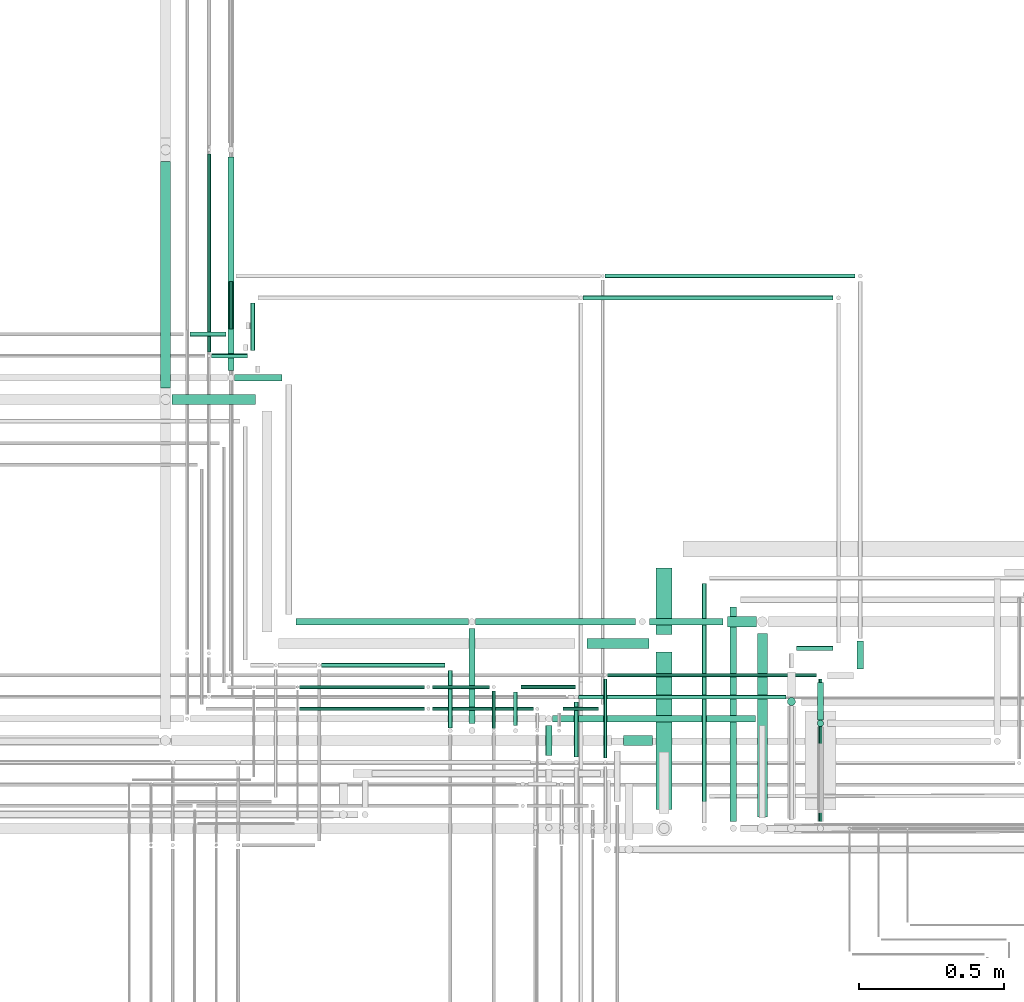
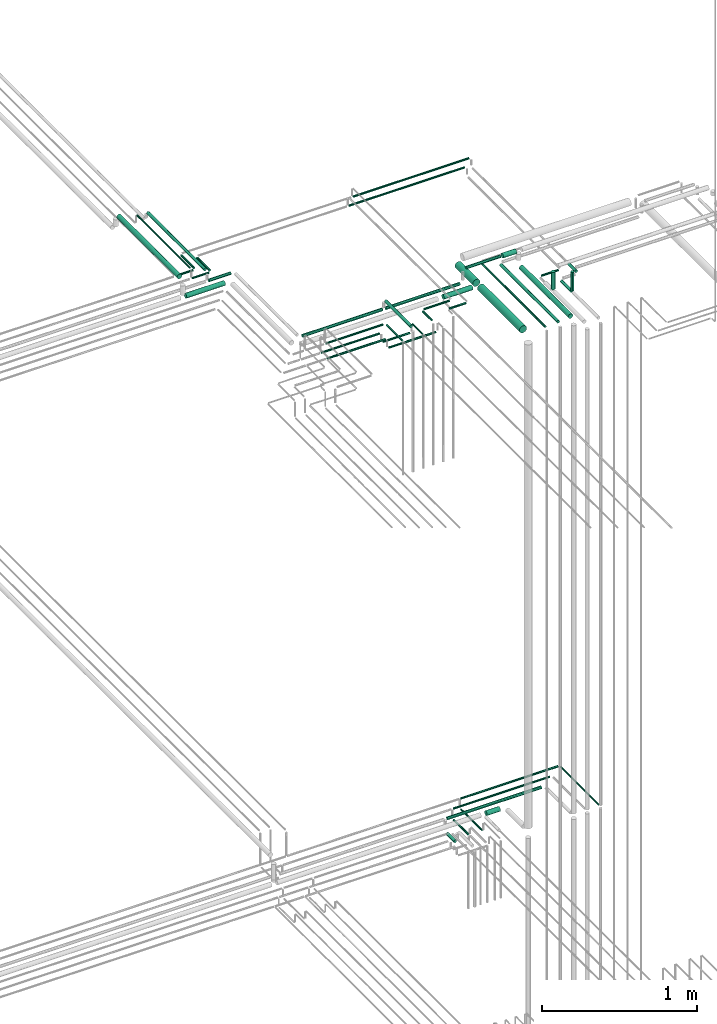
# One storey, part 226 of 331: 45 flow segments.
"""IFC2X3 building model written with IfcOpenShell, lengths in millimetres."""

import ifcopenshell
import ifcopenshell.guid

model = None  # the IFC model being written
_history = None  # IfcOwnerHistory: only IFC2X3 demands one
_inside = {}  # id of a spatial element -> (the spatial element, [elements in it])
_under = {}  # id of a project, library or spatial element -> (it, [spatial elements below it])
_declared = {}  # id of a project -> (the project, [libraries it declares])
_typed = {}  # id of a type object -> (the type object, [elements of that type])
_made_of = {}  # id of a material, layer set ... -> (it, [elements and type objects made of it])


def new_model(schema):
    """Start an empty IFC model of exactly this schema.

    Asked for "IFC4X3", IfcOpenShell would pick the latest addendum, in which some entities
    have other attributes; the version numbers below select the first issue.
    IFC2X3 requires an IfcOwnerHistory on every rooted entity: one is made here for all.
    """
    global model, _history
    if schema == "IFC4X3":
        model = ifcopenshell.file(schema_version=(4, 3, 0, 0))
    else:
        model = ifcopenshell.file(schema=schema)
    _inside.clear()
    _under.clear()
    _declared.clear()
    _typed.clear()
    _made_of.clear()
    _history = None
    if model.schema == "IFC2X3":
        org = make("IfcOrganization", Name="unknown")
        user = make(
            "IfcPersonAndOrganization",
            ThePerson=make("IfcPerson", FamilyName="unknown"),
            TheOrganization=org,
        )
        app = make(
            "IfcApplication",
            ApplicationDeveloper=org,
            Version="unknown",
            ApplicationFullName="unknown",
            ApplicationIdentifier="unknown",
        )
        _history = make(
            "IfcOwnerHistory",
            OwningUser=user,
            OwningApplication=app,
            ChangeAction="ADDED",
            CreationDate=0,
        )
    return model


def make(cls, **values):
    """One entity of the class cls with the attributes given. An attribute that is None is left unset."""
    return model.create_entity(
        cls, **{name: value for name, value in values.items() if value is not None}
    )


def entity(cls, *values):
    """Any entity or typed value of the class cls, its attributes in the order of the schema. None: left unset."""
    e = model.create_entity(cls)
    for i, value in enumerate(values):
        if value is not None:
            e[i] = value
    return e


def rooted(cls, **values):
    """An entity with a GlobalId (a new one), such as an element, a storey or a relation."""
    return make(cls, GlobalId=ifcopenshell.guid.new(), OwnerHistory=_history, **values)


def si_unit(unit_type, name, prefix=None):
    """IfcSIUnit, for example si_unit("LENGTHUNIT", "METRE", prefix="MILLI")."""
    return make("IfcSIUnit", UnitType=unit_type, Prefix=prefix, Name=name)


def converted_unit(unit_type, name, factor, base, dimensions=None, offset=None):
    """IfcConversionBasedUnit, such as the inch: factor (a typed value) times the base unit."""
    return make(
        "IfcConversionBasedUnit"
        if offset is None
        else "IfcConversionBasedUnitWithOffset",
        ConversionOffset=offset,
        Dimensions=None
        if dimensions is None
        else entity("IfcDimensionalExponents", *dimensions),
        UnitType=unit_type,
        Name=name,
        ConversionFactor=make(
            "IfcMeasureWithUnit", ValueComponent=factor, UnitComponent=base
        ),
    )


def derived_unit(unit_type, elements):
    """IfcDerivedUnit: a product of units, each with its exponent."""
    return make(
        "IfcDerivedUnit",
        Elements=[
            make("IfcDerivedUnitElement", Unit=unit, Exponent=power)
            for unit, power in elements
        ],
        UnitType=unit_type,
    )


def assignment(units):
    """IfcUnitAssignment: the units of a project."""
    return None if units is None else make("IfcUnitAssignment", Units=units)


def point(xyz):
    """IfcCartesianPoint."""
    return None if xyz is None else make("IfcCartesianPoint", Coordinates=xyz)


def direction(xyz):
    """IfcDirection."""
    return None if xyz is None else make("IfcDirection", DirectionRatios=xyz)


def frame(location, z_axis=None, x_axis=None):
    """IfcAxis2Placement3D, a coordinate frame: its origin and axes. An axis left out is left unset."""
    return make(
        "IfcAxis2Placement3D",
        Location=point(location),
        Axis=direction(z_axis),
        RefDirection=direction(x_axis),
    )


def frame_2d(location, x_axis=None):
    """IfcAxis2Placement2D, a coordinate frame in the plane: its origin and x axis."""
    return make(
        "IfcAxis2Placement2D", Location=point(location), RefDirection=direction(x_axis)
    )


def origin():
    """The frame at (0, 0, 0) with its axes left unset."""
    return frame((0.0, 0.0, 0.0))


def origin_2d_with_axis():
    """The frame at (0, 0) in the plane with the x axis (1, 0) written out."""
    return frame_2d((0.0, 0.0), x_axis=(1.0, 0.0))


def place(relative_to, where):
    """IfcLocalPlacement: puts the frame where relative to a parent placement (None: the world)."""
    return make(
        "IfcLocalPlacement", PlacementRelTo=relative_to, RelativePlacement=where
    )


def context(
    kind, dimensions, precision=None, world=None, true_north=None, identifier=None
):
    """IfcGeometricRepresentationContext, for example the 3D "Model" context."""
    return make(
        "IfcGeometricRepresentationContext",
        ContextIdentifier=identifier,
        ContextType=kind,
        CoordinateSpaceDimension=dimensions,
        Precision=precision,
        WorldCoordinateSystem=world,
        TrueNorth=true_north,
    )


def subcontext(parent, identifier, kind, view, scale=None):
    """IfcGeometricRepresentationSubContext, for example "Body" below "Model"."""
    return make(
        "IfcGeometricRepresentationSubContext",
        ContextIdentifier=identifier,
        ContextType=kind,
        ParentContext=parent,
        TargetScale=scale,
        TargetView=view,
    )


def project(units=None, contexts=None):
    """IfcProject with its units and contexts."""
    return rooted(
        "IfcProject",
        Name="project",
        RepresentationContexts=contexts,
        UnitsInContext=assignment(units),
    )


def spatial(cls, under=None, at=None, **own):
    """A site, building, storey or space (cls), placed at a placement, below another one or the project."""
    s = rooted(cls, ObjectPlacement=at, **own)
    if under is not None:
        _under.setdefault(under.id(), (under, []))[1].append(s)
    return s


def profile(cls, at=None, kind="AREA", **sizes):
    """A parametric profile (cls). Its sizes go by their IFC names, for example OverallWidth=200.0."""
    return make(cls, ProfileType=kind, Position=at, **sizes)


def circle(**sizes):
    """IfcCircleProfileDef."""
    return profile("IfcCircleProfileDef", **sizes)


def extrude(swept, where, along, depth):
    """IfcExtrudedAreaSolid: the profile swept, set in the frame where, extruded along a direction by depth."""
    return make(
        "IfcExtrudedAreaSolid",
        SweptArea=swept,
        Position=where,
        ExtrudedDirection=direction(along),
        Depth=depth,
    )


def shape(context_of_items, identifier, shape_type, items):
    """IfcShapeRepresentation: the items that make up one representation, for example the "Body"."""
    return make(
        "IfcShapeRepresentation",
        ContextOfItems=context_of_items,
        RepresentationIdentifier=identifier,
        RepresentationType=shape_type,
        Items=items,
    )


def made_of(thing, what):
    """Note that an element or type object is made of a material, layer set ...; save() writes the relation."""
    if what is not None:
        _made_of.setdefault(what.id(), (what, []))[1].append(thing)
    return thing


def type_object(cls, material=None, **own):
    """A type object (cls), such as IfcWallType, which elements share."""
    return made_of(rooted(cls, **own), material)


def element(
    cls,
    number,
    at=None,
    inside=None,
    cuts=None,
    type_object=None,
    material=None,
    context=None,
    identifier="Body",
    shape_type=None,
    held_by="IfcProductDefinitionShape",
    body=None,
    shapes=None,
    **own,
):
    """One element of the class cls, such as IfcWall. Its Tag is "e" and its number.

    at: its placement. inside: the storey or other place that contains it. cuts: it is an
    opening in that element (IfcRelVoidsElement). A single representation is given by context,
    identifier, shape_type and body (its items); several are given by shapes. held_by: the class
    of the entity that holds the representations. save() writes the other relations.
    """
    e = rooted(cls, Tag="e%d" % number, ObjectPlacement=at, **own)
    if body is not None:
        shapes = [shape(context, identifier, shape_type, body)]
    if shapes is not None:
        e.Representation = make(held_by, Representations=shapes)
    if inside is not None:
        _inside.setdefault(inside.id(), (inside, []))[1].append(e)
    if cuts is not None:
        rooted(
            "IfcRelVoidsElement", RelatingBuildingElement=cuts, RelatedOpeningElement=e
        )
    if type_object is not None:
        _typed.setdefault(type_object.id(), (type_object, []))[1].append(e)
    return made_of(e, material)


def aggregate(whole, parts):
    """IfcRelAggregates: a whole, such as a stair, and the parts it consists of."""
    return rooted("IfcRelAggregates", RelatingObject=whole, RelatedObjects=parts)


def save(model, path):
    """Write the relations noted so far, then the file.

    IfcRelAggregates (storeys below a building ...), IfcRelContainedInSpatialStructure (elements
    in a storey), IfcRelDefinesByType, IfcRelAssociatesMaterial and IfcRelDeclares: one each for
    every whole, place, type object, material and project.
    """
    for whole, parts in _under.values():
        aggregate(whole, parts)
    for where, things in _inside.values():
        rooted(
            "IfcRelContainedInSpatialStructure",
            RelatedElements=things,
            RelatingStructure=where,
        )
    for kind, things in _typed.values():
        rooted("IfcRelDefinesByType", RelatedObjects=things, RelatingType=kind)
    for what, things in _made_of.values():
        rooted("IfcRelAssociatesMaterial", RelatedObjects=things, RelatingMaterial=what)
    for by, libraries in _declared.values():
        rooted("IfcRelDeclares", RelatingContext=by, RelatedDefinitions=libraries)
    model.write(path)


model = new_model("IFC2X3")

# Units and contexts
model_context = context("Model", 3, precision=0.01, world=origin(), true_north=direction((6.12303176911189e-17, 1.0)))
body_context = subcontext(model_context, "Body", "Model", "MODEL_VIEW")
ifc_project = project(units=[si_unit("LENGTHUNIT", "METRE", prefix="MILLI"), si_unit("AREAUNIT", "SQUARE_METRE"), si_unit("VOLUMEUNIT", "CUBIC_METRE"), converted_unit("PLANEANGLEUNIT", "DEGREE", entity("IfcRatioMeasure", 0.0174532925199433), si_unit("PLANEANGLEUNIT", "RADIAN"), dimensions=[0, 0, 0, 0, 0, 0, 0]), si_unit("MASSUNIT", "GRAM", prefix="KILO"), derived_unit("MASSDENSITYUNIT", [(si_unit("MASSUNIT", "GRAM", prefix="KILO"), 1), (si_unit("LENGTHUNIT", "METRE"), -3)]), derived_unit("MOMENTOFINERTIAUNIT", [(si_unit("LENGTHUNIT", "METRE"), 4)]), si_unit("TIMEUNIT", "SECOND"), si_unit("FREQUENCYUNIT", "HERTZ"), si_unit("THERMODYNAMICTEMPERATUREUNIT", "DEGREE_CELSIUS"), derived_unit("THERMALTRANSMITTANCEUNIT", [(si_unit("MASSUNIT", "GRAM", prefix="KILO"), 1), (si_unit("THERMODYNAMICTEMPERATUREUNIT", "KELVIN"), -1), (si_unit("TIMEUNIT", "SECOND"), -3)]), derived_unit("VOLUMETRICFLOWRATEUNIT", [(si_unit("LENGTHUNIT", "METRE"), 3), (si_unit("TIMEUNIT", "SECOND"), -1)]), derived_unit("MASSFLOWRATEUNIT", [(si_unit("MASSUNIT", "GRAM", prefix="KILO"), 1), (si_unit("TIMEUNIT", "SECOND"), -1)]), derived_unit("ROTATIONALFREQUENCYUNIT", [(si_unit("TIMEUNIT", "SECOND"), -1)]), si_unit("ELECTRICCURRENTUNIT", "AMPERE"), si_unit("ELECTRICVOLTAGEUNIT", "VOLT"), si_unit("POWERUNIT", "WATT"), si_unit("FORCEUNIT", "NEWTON", prefix="KILO"), si_unit("ILLUMINANCEUNIT", "LUX"), si_unit("LUMINOUSFLUXUNIT", "LUMEN"), si_unit("LUMINOUSINTENSITYUNIT", "CANDELA"), derived_unit("USERDEFINED", [(si_unit("MASSUNIT", "GRAM", prefix="KILO"), -1), (si_unit("LENGTHUNIT", "METRE"), -2), (si_unit("TIMEUNIT", "SECOND"), 3), (si_unit("LUMINOUSFLUXUNIT", "LUMEN"), 1)]), derived_unit("LINEARVELOCITYUNIT", [(si_unit("LENGTHUNIT", "METRE"), 1), (si_unit("TIMEUNIT", "SECOND"), -1)]), si_unit("PRESSUREUNIT", "PASCAL"), derived_unit("USERDEFINED", [(si_unit("LENGTHUNIT", "METRE"), -2), (si_unit("MASSUNIT", "GRAM", prefix="KILO"), 1), (si_unit("TIMEUNIT", "SECOND"), -2)]), derived_unit("LINEARFORCEUNIT", [(si_unit("MASSUNIT", "GRAM", prefix="KILO"), 1), (si_unit("LENGTHUNIT", "METRE"), 1), (si_unit("TIMEUNIT", "SECOND"), -2), (si_unit("LENGTHUNIT", "METRE"), -1)]), derived_unit("PLANARFORCEUNIT", [(si_unit("MASSUNIT", "GRAM", prefix="KILO"), 1), (si_unit("LENGTHUNIT", "METRE"), 1), (si_unit("TIMEUNIT", "SECOND"), -2), (si_unit("LENGTHUNIT", "METRE"), -2)])], contexts=[model_context])

# Site, building, storey
site_placement = place(None, frame((0.0, -0.00077364408347762, 0.0)))
site = spatial("IfcSite", under=ifc_project, at=site_placement, CompositionType="ELEMENT")
building_placement = place(site_placement, origin())
building = spatial("IfcBuilding", under=site, at=building_placement, CompositionType="ELEMENT")
storey_placement = place(building_placement, origin())
storey = spatial("IfcBuildingStorey", under=building, at=storey_placement, CompositionType="ELEMENT", Elevation=0.0)

# Flow segments
pipe_segment_type = type_object("IfcPipeSegmentType", PredefinedType="NOTDEFINED")
flow_segment_1_placement = place(storey_placement, frame((64243.5166110417, 8171.93026688113, 14542.4047277641)))
element("IfcFlowSegment", 1, at=flow_segment_1_placement, inside=storey, type_object=pipe_segment_type, context=body_context, shape_type="SweptSolid", body=[
    extrude(circle(Radius=6.0, at=origin_2d_with_axis()), frame((7.59527223591454, 0.0, 7.5952722359167), z_axis=(0.0, 1.0, 0.0), x_axis=(-1.0, 0.0, 0.0)), (0.0, 0.0, 1.0), 489.690296946231),
])
flow_segment_2_placement = place(storey_placement, frame((63502.5166110417, 8389.62056382736, 14467.4047277641)))
element("IfcFlowSegment", 2, at=flow_segment_2_placement, inside=storey, type_object=pipe_segment_type, context=body_context, shape_type="SweptSolid", body=[
    extrude(circle(Radius=6.0, at=frame_2d((-8.66293703438714e-12, 0.0), x_axis=(1.0, 0.0))), frame((7.59527223591454, 0.0, 7.5952722359167), z_axis=(0.0, 1.0, 0.0), x_axis=(-1.0, 0.0, 0.0)), (0.0, 0.0, 1.0), 272.000000000005),
])
flow_segment_3_placement = place(storey_placement, frame((63517.1118832777, 8668.02529159145, 14542.4047277641)))
element("IfcFlowSegment", 3, at=flow_segment_3_placement, inside=storey, type_object=pipe_segment_type, context=body_context, shape_type="SweptSolid", body=[
    extrude(circle(Radius=6.0, at=origin_2d_with_axis()), frame((0.0, 7.59527223591562, 7.5952722359167), z_axis=(1.0, 0.0, 0.0), x_axis=(0.0, 1.0, 0.0)), (0.0, 0.0, 1.0), 719.999999999949),
])
flow_segment_4_placement = place(storey_placement, frame((63401.0132627126, 8393.62056382736, 14465.9047277641)))
element("IfcFlowSegment", 4, at=flow_segment_4_placement, inside=storey, type_object=pipe_segment_type, context=body_context, shape_type="SweptSolid", body=[
    extrude(circle(Radius=7.5, at=origin_2d_with_axis()), frame((9.09527223591419, 0.0, 9.09527223591636), z_axis=(0.0, 1.0, 0.0), x_axis=(1.0, 0.0, 0.0)), (0.0, 0.0, 1.0), 189.000000000011),
])
flow_segment_5_placement = place(storey_placement, frame((63418.1085349485, 8591.52529159145, 14540.9047277641)))
element("IfcFlowSegment", 5, at=flow_segment_5_placement, inside=storey, type_object=pipe_segment_type, context=body_context, shape_type="SweptSolid", body=[
    extrude(circle(Radius=7.5, at=frame_2d((-2.16573425859679e-12, -2.16573425859679e-12), x_axis=(1.0, 0.0))), frame((0.0, 9.09527223591744, 9.09527223591853), z_axis=(1.0, 0.0, 0.0), x_axis=(0.0, 1.0, 0.0)), (0.0, 0.0, 1.0), 715.003348329104),
])
flow_segment_6_placement = place(storey_placement, frame((63303.2157915365, 8399.62056382736, 14437.4047277641)))
element("IfcFlowSegment", 6, at=flow_segment_6_placement, inside=storey, type_object=pipe_segment_type, context=body_context, shape_type="SweptSolid", body=[
    extrude(circle(Radius=11.0, at=origin_2d_with_axis()), frame((12.5952722359134, 0.0, 12.5952722359156), z_axis=(0.0, 1.0, 0.0), x_axis=(1.0, 0.0, 0.0)), (0.0, 0.0, 1.0), 101.999999999997),
])
flow_segment_7_placement = place(storey_placement, frame((63327.8110637724, 8513.02529159144, 14537.4047277641)))
element("IfcFlowSegment", 7, at=flow_segment_7_placement, inside=storey, type_object=pipe_segment_type, context=body_context, shape_type="SweptSolid", body=[
    extrude(circle(Radius=11.0, at=frame_2d((4.33146851719357e-12, 0.0), x_axis=(1.0, 0.0))), frame((0.0, 12.5952722359199, 12.5952722359156), z_axis=(1.0, 0.0, 0.0), x_axis=(0.0, 1.0, 0.0)), (0.0, 0.0, 1.0), 699.300819505229),
])
flow_segment_8_placement = place(storey_placement, frame((63572.7911522121, 8431.52529159144, 14530.9047277641)))
element("IfcFlowSegment", 8, at=flow_segment_8_placement, inside=storey, type_object=pipe_segment_type, context=body_context, shape_type="SweptSolid", body=[
    extrude(circle(Radius=17.5, at=frame_2d((4.33146851719357e-12, 0.0), x_axis=(1.0, 0.0))), frame((0.0, 19.0952722359206, 19.0952722359163), z_axis=(1.0, 0.0, 0.0), x_axis=(0.0, 1.0, 0.0)), (0.0, 0.0, 1.0), 99.8207310654797),
])
flow_segment_9_placement = place(storey_placement, frame((63684.0166110417, 8814.81073448216, 18421.4047277641)))
element("IfcFlowSegment", 9, at=flow_segment_9_placement, inside=storey, type_object=pipe_segment_type, context=body_context, shape_type="SweptSolid", body=[
    extrude(circle(Radius=27.0, at=origin_2d_with_axis()), frame((28.5952722359184, 0.0, 28.5952722359163), z_axis=(0.0, 1.0, 0.0), x_axis=(1.0, 0.0, 0.0)), (0.0, 0.0, 1.0), 230.33768870981),
])
flow_segment_10_placement = place(storey_placement, frame((63841.9181368167, 8165.92998971294, 18440.9046193653)))
element("IfcFlowSegment", 10, at=flow_segment_10_placement, inside=storey, type_object=pipe_segment_type, context=body_context, shape_type="SweptSolid", body=[
    extrude(circle(Radius=7.5, at=frame_2d((0.0, -2.16573425859679e-12), x_axis=(1.0, 0.0))), frame((9.09527223591419, 0.0, 9.09527223591419), z_axis=(0.0, 1.0, 0.0), x_axis=(1.0, 0.0, 0.0)), (0.0, 0.0, 1.0), 825.880744769251),
])
flow_segment_11_placement = place(storey_placement, frame((63938.5166110417, 8171.9299721304, 18437.4047277641)))
element("IfcFlowSegment", 11, at=flow_segment_11_placement, inside=storey, type_object=pipe_segment_type, context=body_context, shape_type="SweptSolid", body=[
    extrude(circle(Radius=11.0, at=origin_2d_with_axis()), frame((12.5952722359134, 0.0, 12.5952722359156), z_axis=(0.0, 1.0, 0.0), x_axis=(1.0, 0.0, 0.0)), (0.0, 0.0, 1.0), 738.880762351797),
])
flow_segment_12_placement = place(storey_placement, frame((64032.0166110417, 8187.93026688085, 18430.9047277641)))
element("IfcFlowSegment", 12, at=flow_segment_12_placement, inside=storey, type_object=pipe_segment_type, context=body_context, shape_type="SweptSolid", body=[
    extrude(circle(Radius=17.5, at=origin_2d_with_axis()), frame((19.0952722359206, 0.0, 19.0952722359163), z_axis=(0.0, 1.0, 0.0), x_axis=(1.0, 0.0, 0.0)), (0.0, 0.0, 1.0), 631.880467601303),
])
flow_segment_13_placement = place(storey_placement, frame((63930.6118832776, 8840.71546224621, 18540.9047277641)))
element("IfcFlowSegment", 13, at=flow_segment_13_placement, inside=storey, type_object=pipe_segment_type, context=body_context, shape_type="SweptSolid", body=[
    extrude(circle(Radius=17.5, at=frame_2d((1.29944055515807e-11, 0.0), x_axis=(1.0, 0.0))), frame((0.0, 19.0952722359292, 19.0952722359184), z_axis=(1.0, 0.0, 0.0), x_axis=(0.0, 1.0, 0.0)), (0.0, 0.0, 1.0), 99.500000000038),
])
flow_segment_14_placement = place(storey_placement, frame((63661.6118832776, 8847.21546224621, 18547.4047277641)))
element("IfcFlowSegment", 14, at=flow_segment_14_placement, inside=storey, type_object=pipe_segment_type, context=body_context, shape_type="SweptSolid", body=[
    extrude(circle(Radius=11.0, at=frame_2d((-3.24860138789518e-12, 0.0), x_axis=(1.0, 0.0))), frame((0.0, 12.5952722359188, 12.5952722359156), z_axis=(1.0, 0.0, 0.0), x_axis=(0.0, 1.0, 0.0)), (0.0, 0.0, 1.0), 254.000000000003),
])
flow_segment_15_placement = place(storey_placement, frame((63684.0166110417, 8212.93026688114, 18421.4047277641)))
element("IfcFlowSegment", 15, at=flow_segment_15_placement, inside=storey, type_object=pipe_segment_type, context=body_context, shape_type="SweptSolid", body=[
    extrude(circle(Radius=27.0, at=origin_2d_with_axis()), frame((28.5952722359184, 0.0, 28.5952722359163), z_axis=(0.0, 1.0, 0.0), x_axis=(1.0, 0.0, 0.0)), (0.0, 0.0, 1.0), 541.880467601019),
])
flow_segment_16_placement = place(storey_placement, frame((64238.5166110417, 8521.81073448247, 18362.4047277641)))
element("IfcFlowSegment", 16, at=flow_segment_16_placement, inside=storey, type_object=pipe_segment_type, context=body_context, shape_type="SweptSolid", body=[
    extrude(circle(Radius=11.0, at=origin_2d_with_axis()), frame((12.5952722359134, 0.0, 12.5952722359156), z_axis=(0.0, 1.0, 0.0), x_axis=(1.0, 0.0, 0.0)), (0.0, 0.0, 1.0), 127.843376210776),
])
flow_segment_17_placement = place(storey_placement, frame((63434.1118832776, 9965.904727764, 18440.9047277641)))
element("IfcFlowSegment", 17, at=flow_segment_17_placement, inside=storey, type_object=pipe_segment_type, context=body_context, shape_type="SweptSolid", body=[
    extrude(circle(Radius=7.5, at=frame_2d((0.0, 2.16573425859679e-12), x_axis=(1.0, 0.0))), frame((0.0, 9.09527223592069, 9.09527223591853), z_axis=(1.0, 0.0, 0.0), x_axis=(0.0, -1.0, 0.0)), (0.0, 0.0, 1.0), 861.000000000047),
])
flow_segment_18_placement = place(storey_placement, frame((63038.5166110417, 8508.81073448244, 18512.4047277641)))
element("IfcFlowSegment", 18, at=flow_segment_18_placement, inside=storey, type_object=pipe_segment_type, context=body_context, shape_type="SweptSolid", body=[
    extrude(circle(Radius=11.0, at=frame_2d((-3.46517481375486e-11, 0.0), x_axis=(1.0, 0.0))), frame((12.5952722359481, 0.0, 12.5952722359156), z_axis=(0.0, 1.0, 0.0), x_axis=(-1.0, 0.0, 0.0)), (0.0, 0.0, 1.0), 326.999999999654),
])
flow_segment_19_placement = place(storey_placement, frame((62967.0166110417, 8492.81073448244, 18440.9047277641)))
element("IfcFlowSegment", 19, at=flow_segment_19_placement, inside=storey, type_object=pipe_segment_type, context=body_context, shape_type="SweptSolid", body=[
    extrude(circle(Radius=7.5, at=frame_2d((-1.73258740687743e-11, -2.16573425859679e-12), x_axis=(1.0, 0.0))), frame((9.09527223591419, 0.0, 9.09527223591853), z_axis=(0.0, 1.0, 0.0), x_axis=(-1.0, 0.0, 0.0)), (0.0, 0.0, 1.0), 198.999999999993),
])
flow_segment_20_placement = place(storey_placement, frame((63118.5166110417, 8491.81073448244, 18442.4047277641)))
element("IfcFlowSegment", 20, at=flow_segment_20_placement, inside=storey, type_object=pipe_segment_type, context=body_context, shape_type="SweptSolid", body=[
    extrude(circle(Radius=6.0, at=origin_2d_with_axis()), frame((7.59527223591454, 0.0, 7.5952722359167), z_axis=(0.0, 1.0, 0.0), x_axis=(1.0, 0.0, 0.0)), (0.0, 0.0, 1.0), 129.000000000003),
])
flow_segment_21_placement = place(storey_placement, frame((62915.1118832776, 8552.21546224652, 18367.4047277641)))
element("IfcFlowSegment", 21, at=flow_segment_21_placement, inside=storey, type_object=pipe_segment_type, context=body_context, shape_type="SweptSolid", body=[
    extrude(circle(Radius=6.0, at=frame_2d((1.08286712929839e-12, 0.0), x_axis=(1.0, 0.0))), frame((0.0, 7.5952722359167, 7.5952722359167), z_axis=(1.0, 0.0, 0.0), x_axis=(0.0, 1.0, 0.0)), (0.0, 0.0, 1.0), 347.000000000016),
])
flow_segment_22_placement = place(storey_placement, frame((62915.1118832776, 8627.21546224653, 18367.4047277641)))
element("IfcFlowSegment", 22, at=flow_segment_22_placement, inside=storey, type_object=pipe_segment_type, context=body_context, shape_type="SweptSolid", body=[
    extrude(circle(Radius=6.0, at=origin_2d_with_axis()), frame((0.0, 7.59527223591562, 7.5952722359167), z_axis=(1.0, 0.0, 0.0), x_axis=(0.0, 1.0, 0.0)), (0.0, 0.0, 1.0), 196.99999999999),
])
flow_segment_23_placement = place(storey_placement, frame((64238.5166110417, 8497.21546224655, 18387.0)))
element("IfcFlowSegment", 23, at=flow_segment_23_placement, inside=storey, type_object=pipe_segment_type, context=body_context, shape_type="SweptSolid", body=[
    extrude(circle(Radius=11.0, at=origin_2d_with_axis()), frame((12.5952722359134, 12.5952722359156, 0.0), z_axis=(0.0, 0.0, 1.0), x_axis=(-1.0, 0.0, 0.0)), (0.0, 0.0, 1.0), 148.999999999996),
])
flow_segment_24_placement = place(storey_placement, frame((61977.0947663298, 9665.0, 18565.9047277641)))
element("IfcFlowSegment", 24, at=flow_segment_24_placement, inside=storey, type_object=pipe_segment_type, context=body_context, shape_type="SweptSolid", body=[
    extrude(circle(Radius=17.5, at=origin_2d_with_axis()), frame((19.0952722359119, 0.0, 19.0952722359163), z_axis=(0.0, 1.0, 0.0), x_axis=(1.0, 0.0, 0.0)), (0.0, 0.0, 1.0), 779.810734482275),
])
flow_segment_25_placement = place(storey_placement, frame((62017.1900385657, 9605.904727764, 18430.9047277641)))
element("IfcFlowSegment", 25, at=flow_segment_25_placement, inside=storey, type_object=pipe_segment_type, context=body_context, shape_type="SweptSolid", body=[
    extrude(circle(Radius=17.5, at=origin_2d_with_axis()), frame((0.0, 19.0952722359163, 19.0952722359163), z_axis=(1.0, 0.0, 0.0), x_axis=(0.0, 1.0, 0.0)), (0.0, 0.0, 1.0), 288.334313866084),
])
flow_segment_26_placement = place(storey_placement, frame((62138.5947663296, 9789.0, 18517.4047277641)))
element("IfcFlowSegment", 26, at=flow_segment_26_placement, inside=storey, type_object=pipe_segment_type, context=body_context, shape_type="SweptSolid", body=[
    extrude(circle(Radius=6.0, at=frame_2d((0.0, 2.16573425859679e-12), x_axis=(1.0, 0.0))), frame((7.59527223591454, 0.0, 7.59527223591887), z_axis=(0.0, 1.0, 0.0), x_axis=(1.0, 0.0, 0.0)), (0.0, 0.0, 1.0), 681.810734482274),
])
flow_segment_27_placement = place(storey_placement, frame((62154.1900385655, 9765.904727764, 18440.9047277641)))
element("IfcFlowSegment", 27, at=flow_segment_27_placement, inside=storey, type_object=pipe_segment_type, context=body_context, shape_type="SweptSolid", body=[
    extrude(circle(Radius=7.5, at=frame_2d((2.16573425859679e-12, 0.0), x_axis=(1.0, 0.0))), frame((0.0, 9.09527223591853, 9.09527223591636), z_axis=(1.0, 0.0, 0.0), x_axis=(0.0, 1.0, 0.0)), (0.0, 0.0, 1.0), 124.000000000275),
])
flow_segment_28_placement = place(storey_placement, frame((62208.5947663298, 9724.0, 18512.4047277641)))
element("IfcFlowSegment", 28, at=flow_segment_28_placement, inside=storey, type_object=pipe_segment_type, context=body_context, shape_type="SweptSolid", body=[
    extrude(circle(Radius=11.0, at=frame_2d((0.0, 2.16573425859679e-12), x_axis=(1.0, 0.0))), frame((12.5952722359394, 0.0, 12.5952722359177), z_axis=(0.0, 1.0, 0.0), x_axis=(1.0, 0.0, 0.0)), (0.0, 0.0, 1.0), 736.810734482276),
])
flow_segment_29_placement = place(storey_placement, frame((62233.1900385657, 9687.404727764, 18437.4047277641)))
element("IfcFlowSegment", 29, at=flow_segment_29_placement, inside=storey, type_object=pipe_segment_type, context=body_context, shape_type="SweptSolid", body=[
    extrude(circle(Radius=11.0, at=frame_2d((6.49720277579036e-12, 0.0), x_axis=(1.0, 0.0))), frame((0.0, 12.5952722359221, 12.5952722359156), z_axis=(1.0, 0.0, 0.0), x_axis=(0.0, 1.0, 0.0)), (0.0, 0.0, 1.0), 163.33431386606),
])
flow_segment_30_placement = place(storey_placement, frame((62079.1900385657, 9840.904727764, 18440.9047277641)))
element("IfcFlowSegment", 30, at=flow_segment_30_placement, inside=storey, type_object=pipe_segment_type, context=body_context, shape_type="SweptSolid", body=[
    extrude(circle(Radius=7.5, at=frame_2d((-2.16573425859679e-12, -2.16573425859679e-12), x_axis=(1.0, 0.0))), frame((0.0, 9.09527223591853, 9.09527223591853), z_axis=(1.0, 0.0, 0.0), x_axis=(0.0, 1.0, 0.0)), (0.0, 0.0, 1.0), 123.999999999773),
])
flow_segment_31_placement = place(building_placement, frame((63063.1118832777, 8847.21546224618, 18437.4047277641)))
element("IfcFlowSegment", 31, at=flow_segment_31_placement, inside=storey, type_object=pipe_segment_type, context=body_context, shape_type="SweptSolid", body=[
    extrude(circle(Radius=11.0, at=frame_2d((1.29944055515807e-11, -2.16573425859679e-12), x_axis=(1.0, 0.0))), frame((0.0, 12.5952722359286, 12.5952722359177), z_axis=(1.0, 0.0, 0.0), x_axis=(0.0, 1.0, 0.0)), (0.0, 0.0, 1.0), 550.499999999892),
])
flow_segment_32_placement = place(building_placement, frame((64375.5166110417, 8697.65411069323, 18362.4047277641)))
element("IfcFlowSegment", 32, at=flow_segment_32_placement, inside=storey, type_object=pipe_segment_type, context=body_context, shape_type="SweptSolid", body=[
    extrude(circle(Radius=11.0, at=frame_2d((0.0, -2.16573425859679e-12), x_axis=(1.0, 0.0))), frame((12.5952722359134, 0.0, 12.5952722359134), z_axis=(0.0, 1.0, 0.0), x_axis=(1.0, 0.0, 0.0)), (0.0, 0.0, 1.0), 96.0000000000085),
])
flow_segment_33_placement = place(storey_placement, frame((64169.1118832776, 8758.83499464523, 18365.9047277641)))
element("IfcFlowSegment", 33, at=flow_segment_33_placement, inside=storey, type_object=pipe_segment_type, context=body_context, shape_type="SweptSolid", body=[
    extrude(circle(Radius=7.5, at=origin_2d_with_axis()), frame((0.0, 9.09527223591636, 9.09527223591636), z_axis=(1.0, 0.0, 0.0), x_axis=(0.0, -1.0, 0.0)), (0.0, 0.0, 1.0), 126.000000000041),
])
flow_segment_34_placement = place(storey_placement, frame((64135.5166110417, 8569.21546224655, 18390.0)))
element("IfcFlowSegment", 34, at=flow_segment_34_placement, inside=storey, type_object=pipe_segment_type, context=body_context, shape_type="SweptSolid", body=[
    extrude(circle(Radius=14.0, at=origin_2d_with_axis()), frame((15.5952722359127, 15.595272235916, 0.0), z_axis=(0.0, 0.0, 1.0), x_axis=(-1.0, 0.0, 0.0)), (0.0, 0.0, 1.0), 136.000000000023),
])
flow_segment_35_placement = place(storey_placement, frame((62444.5243524318, 8847.21546224618, 18437.4047277641)))
element("IfcFlowSegment", 35, at=flow_segment_35_placement, inside=storey, type_object=pipe_segment_type, context=body_context, shape_type="SweptSolid", body=[
    extrude(circle(Radius=11.0, at=frame_2d((3.24860138789518e-12, 0.0), x_axis=(1.0, 0.0))), frame((0.0, 12.5952722359177, 12.5952722359156), z_axis=(1.0, 0.0, 0.0), x_axis=(0.0, 1.0, 0.0)), (0.0, 0.0, 1.0), 594.587530845901),
])
flow_segment_36_placement = place(building_placement, frame((63365.1118832776, 8552.21546224652, 18517.4047277641)))
element("IfcFlowSegment", 36, at=flow_segment_36_placement, inside=storey, type_object=pipe_segment_type, context=body_context, shape_type="SweptSolid", body=[
    extrude(circle(Radius=6.0, at=origin_2d_with_axis()), frame((0.0, 7.59527223592212, 7.5952722359167), z_axis=(1.0, 0.0, 0.0), x_axis=(0.0, -1.0, 0.0)), (0.0, 0.0, 1.0), 122.000000000024),
])
flow_segment_37_placement = place(storey_placement, frame((63509.1118832776, 10040.904727764, 18440.9047277641)))
element("IfcFlowSegment", 37, at=flow_segment_37_placement, inside=storey, type_object=pipe_segment_type, context=body_context, shape_type="SweptSolid", body=[
    extrude(circle(Radius=7.5, at=frame_2d((-2.16573425859679e-12, -2.16573425859679e-12), x_axis=(1.0, 0.0))), frame((0.0, 9.09527223591853, 9.09527223591853), z_axis=(1.0, 0.0, 0.0), x_axis=(0.0, 1.0, 0.0)), (0.0, 0.0, 1.0), 861.000000000047),
])
flow_segment_38_placement = place(building_placement, frame((63219.1118832777, 8625.71546224653, 18515.9047277641)))
element("IfcFlowSegment", 38, at=flow_segment_38_placement, inside=storey, type_object=pipe_segment_type, context=body_context, shape_type="SweptSolid", body=[
    extrude(circle(Radius=7.5, at=frame_2d((-3.24860138789518e-12, 0.0), x_axis=(1.0, 0.0))), frame((0.0, 9.09527223592069, 9.09527223591636), z_axis=(1.0, 0.0, 0.0), x_axis=(0.0, 1.0, 0.0)), (0.0, 0.0, 1.0), 188.999999999974),
])
flow_segment_39_placement = place(building_placement, frame((63192.0166110417, 8502.81073448245, 18515.9047277641)))
element("IfcFlowSegment", 39, at=flow_segment_39_placement, inside=storey, type_object=pipe_segment_type, context=body_context, shape_type="SweptSolid", body=[
    extrude(circle(Radius=7.5, at=frame_2d((0.0, -2.16573425859679e-12), x_axis=(1.0, 0.0))), frame((9.09527223591419, 0.0, 9.09527223591419), z_axis=(0.0, 1.0, 0.0), x_axis=(1.0, 0.0, 0.0)), (0.0, 0.0, 1.0), 114.00000000001),
])
flow_segment_40_placement = place(building_placement, frame((62212.0947663295, 9868.0, 18440.9047277641)))
element("IfcFlowSegment", 40, at=flow_segment_40_placement, inside=storey, type_object=pipe_segment_type, context=body_context, shape_type="SweptSolid", body=[
    extrude(circle(Radius=7.5, at=origin_2d_with_axis()), frame((9.09527223591419, 0.0, 9.09527223591636), z_axis=(0.0, 1.0, 0.0), x_axis=(-1.0, 0.0, 0.0)), (0.0, 0.0, 1.0), 164.000000000008),
])
flow_segment_41_placement = place(building_placement, frame((62287.0947663298, 9793.0, 18440.9047277641)))
element("IfcFlowSegment", 41, at=flow_segment_41_placement, inside=storey, type_object=pipe_segment_type, context=body_context, shape_type="SweptSolid", body=[
    extrude(circle(Radius=7.5, at=frame_2d((8.66293703438714e-12, 0.0), x_axis=(1.0, 0.0))), frame((9.09527223592286, 0.0, 9.09527223591636), z_axis=(0.0, 1.0, 0.0), x_axis=(-1.0, 0.0, 0.0)), (0.0, 0.0, 1.0), 164.000000000002),
])
flow_segment_42_placement = place(building_placement, frame((63447.1118832776, 8765.71546224623, 18430.9047277641)))
element("IfcFlowSegment", 42, at=flow_segment_42_placement, inside=storey, type_object=pipe_segment_type, context=body_context, shape_type="SweptSolid", body=[
    extrude(circle(Radius=17.5, at=frame_2d((4.33146851719357e-12, 0.0), x_axis=(1.0, 0.0))), frame((0.0, 19.0952722359206, 19.0952722359163), z_axis=(1.0, 0.0, 0.0), x_axis=(0.0, 1.0, 0.0)), (0.0, 0.0, 1.0), 213.499999999934),
])
flow_segment_43_placement = place(storey_placement, frame((62533.0088035031, 8700.71546224652, 18440.9047277641)))
element("IfcFlowSegment", 43, at=flow_segment_43_placement, inside=storey, type_object=pipe_segment_type, context=body_context, shape_type="SweptSolid", body=[
    extrude(circle(Radius=7.5, at=frame_2d((-1.08286712929839e-12, -2.16573425859679e-12), x_axis=(1.0, 0.0))), frame((0.0, 9.09527223591853, 9.09527223591853), z_axis=(1.0, 0.0, 0.0), x_axis=(0.0, 1.0, 0.0)), (0.0, 0.0, 1.0), 425.10307977457),
])
flow_segment_44_placement = place(storey_placement, frame((62457.0088035031, 8627.21546224653, 18442.4047277641)))
element("IfcFlowSegment", 44, at=flow_segment_44_placement, inside=storey, type_object=pipe_segment_type, context=body_context, shape_type="SweptSolid", body=[
    extrude(circle(Radius=6.0, at=frame_2d((-1.08286712929839e-12, -2.16573425859679e-12), x_axis=(1.0, 0.0))), frame((0.0, 7.5952722359167, 7.59527223591887), z_axis=(1.0, 0.0, 0.0), x_axis=(0.0, 1.0, 0.0)), (0.0, 0.0, 1.0), 430.103079774569),
])
flow_segment_45_placement = place(storey_placement, frame((62457.0088035031, 8552.21546224652, 18442.4047277642)))
element("IfcFlowSegment", 45, at=flow_segment_45_placement, inside=storey, type_object=pipe_segment_type, context=body_context, shape_type="SweptSolid", body=[
    extrude(circle(Radius=6.0, at=frame_2d((4.33146851719357e-12, 0.0), x_axis=(1.0, 0.0))), frame((0.0, 7.59527223591778, 7.5952722359167), z_axis=(1.0, 0.0, 0.0), x_axis=(0.0, 1.0, 0.0)), (0.0, 0.0, 1.0), 430.103079774551),
])

save(model, "model.ifc")
